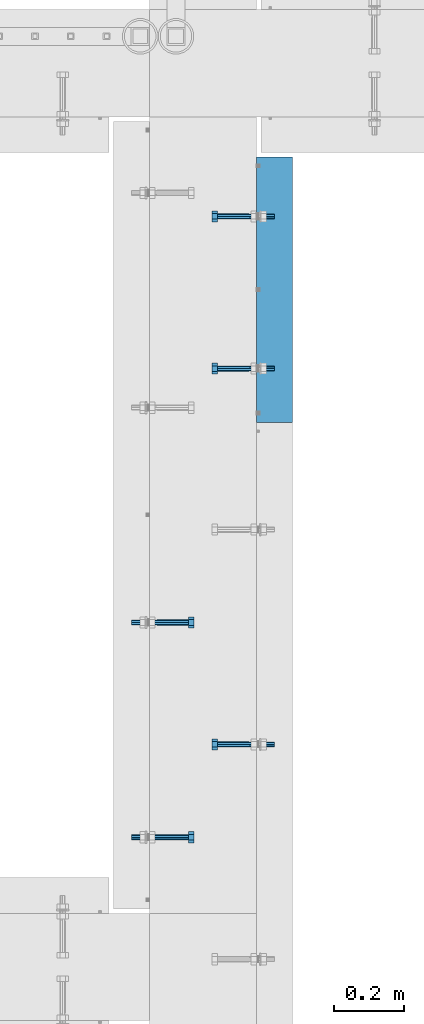
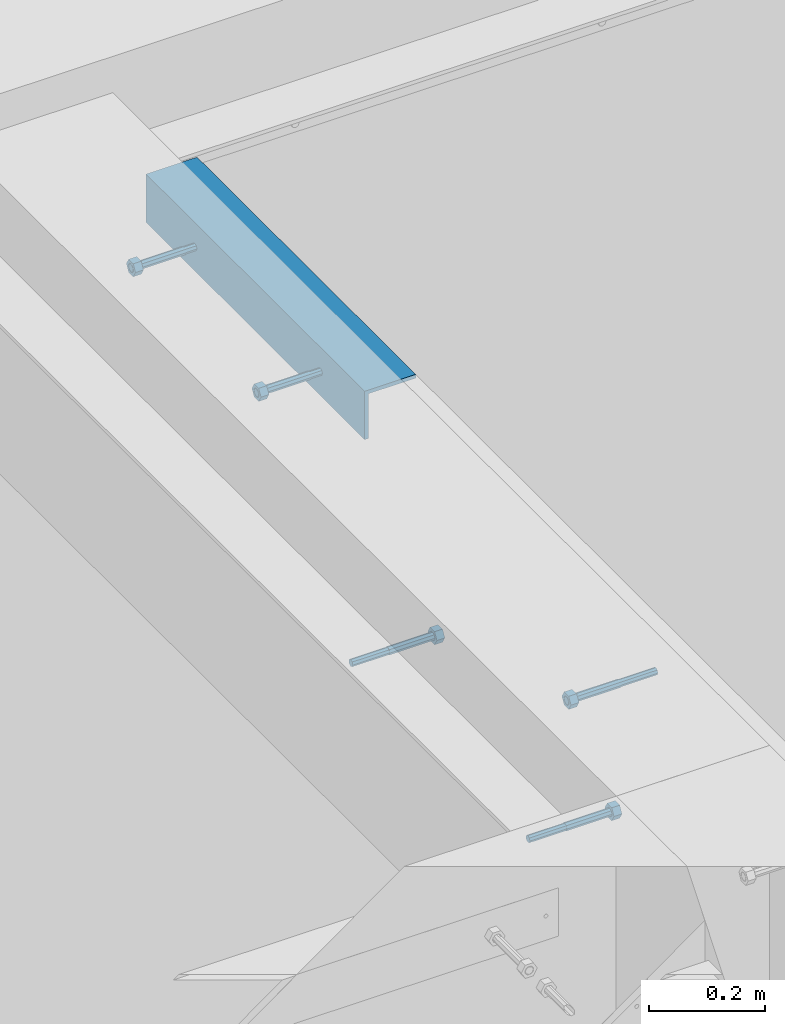
# One storey, part 424 of 975: 6 beams.
"""IFC2X3 building model written with IfcOpenShell, lengths in millimetres."""

import ifcopenshell
import ifcopenshell.guid

model = None  # the IFC model being written
_history = None  # IfcOwnerHistory: only IFC2X3 demands one
_inside = {}  # id of a spatial element -> (the spatial element, [elements in it])
_under = {}  # id of a project, library or spatial element -> (it, [spatial elements below it])
_declared = {}  # id of a project -> (the project, [libraries it declares])
_typed = {}  # id of a type object -> (the type object, [elements of that type])
_made_of = {}  # id of a material, layer set ... -> (it, [elements and type objects made of it])


def new_model(schema):
    """Start an empty IFC model of exactly this schema.

    Asked for "IFC4X3", IfcOpenShell would pick the latest addendum, in which some entities
    have other attributes; the version numbers below select the first issue.
    IFC2X3 requires an IfcOwnerHistory on every rooted entity: one is made here for all.
    """
    global model, _history
    if schema == "IFC4X3":
        model = ifcopenshell.file(schema_version=(4, 3, 0, 0))
    else:
        model = ifcopenshell.file(schema=schema)
    _inside.clear()
    _under.clear()
    _declared.clear()
    _typed.clear()
    _made_of.clear()
    _history = None
    if model.schema == "IFC2X3":
        org = make("IfcOrganization", Name="unknown")
        user = make(
            "IfcPersonAndOrganization",
            ThePerson=make("IfcPerson", FamilyName="unknown"),
            TheOrganization=org,
        )
        app = make(
            "IfcApplication",
            ApplicationDeveloper=org,
            Version="unknown",
            ApplicationFullName="unknown",
            ApplicationIdentifier="unknown",
        )
        _history = make(
            "IfcOwnerHistory",
            OwningUser=user,
            OwningApplication=app,
            ChangeAction="ADDED",
            CreationDate=0,
        )
    return model


def make(cls, **values):
    """One entity of the class cls with the attributes given. An attribute that is None is left unset."""
    return model.create_entity(
        cls, **{name: value for name, value in values.items() if value is not None}
    )


def rooted(cls, **values):
    """An entity with a GlobalId (a new one), such as an element, a storey or a relation."""
    return make(cls, GlobalId=ifcopenshell.guid.new(), OwnerHistory=_history, **values)


def si_unit(unit_type, name, prefix=None):
    """IfcSIUnit, for example si_unit("LENGTHUNIT", "METRE", prefix="MILLI")."""
    return make("IfcSIUnit", UnitType=unit_type, Prefix=prefix, Name=name)


def assignment(units):
    """IfcUnitAssignment: the units of a project."""
    return None if units is None else make("IfcUnitAssignment", Units=units)


def point(xyz):
    """IfcCartesianPoint."""
    return None if xyz is None else make("IfcCartesianPoint", Coordinates=xyz)


def direction(xyz):
    """IfcDirection."""
    return None if xyz is None else make("IfcDirection", DirectionRatios=xyz)


def frame(location, z_axis=None, x_axis=None):
    """IfcAxis2Placement3D, a coordinate frame: its origin and axes. An axis left out is left unset."""
    return make(
        "IfcAxis2Placement3D",
        Location=point(location),
        Axis=direction(z_axis),
        RefDirection=direction(x_axis),
    )


def origin_with_axes():
    """The frame at (0, 0, 0) with the z axis (0, 0, 1) and the x axis (1, 0, 0) written out."""
    return frame((0.0, 0.0, 0.0), z_axis=(0.0, 0.0, 1.0), x_axis=(1.0, 0.0, 0.0))


def place(relative_to, where):
    """IfcLocalPlacement: puts the frame where relative to a parent placement (None: the world)."""
    return make(
        "IfcLocalPlacement", PlacementRelTo=relative_to, RelativePlacement=where
    )


def context(
    kind, dimensions, precision=None, world=None, true_north=None, identifier=None
):
    """IfcGeometricRepresentationContext, for example the 3D "Model" context."""
    return make(
        "IfcGeometricRepresentationContext",
        ContextIdentifier=identifier,
        ContextType=kind,
        CoordinateSpaceDimension=dimensions,
        Precision=precision,
        WorldCoordinateSystem=world,
        TrueNorth=true_north,
    )


def subcontext(parent, identifier, kind, view, scale=None):
    """IfcGeometricRepresentationSubContext, for example "Body" below "Model"."""
    return make(
        "IfcGeometricRepresentationSubContext",
        ContextIdentifier=identifier,
        ContextType=kind,
        ParentContext=parent,
        TargetScale=scale,
        TargetView=view,
    )


def project(units=None, contexts=None):
    """IfcProject with its units and contexts."""
    return rooted(
        "IfcProject",
        Name="project",
        RepresentationContexts=contexts,
        UnitsInContext=assignment(units),
    )


def spatial(cls, under=None, at=None, **own):
    """A site, building, storey or space (cls), placed at a placement, below another one or the project."""
    s = rooted(cls, ObjectPlacement=at, **own)
    if under is not None:
        _under.setdefault(under.id(), (under, []))[1].append(s)
    return s


def faces_of(points, faces, orient=None, outer=None):
    """IfcFace entities. A face is a list of loops; a loop is a list of indices into points, from 0.

    orient and outer hold one flag for each loop. By default every Orientation is true, the
    first loop of a face is its IfcFaceOuterBound and the others are IfcFaceBound.
    """
    made = []
    for i, loops in enumerate(faces):
        bounds = []
        for j, loop in enumerate(loops):
            is_outer = j == 0 if outer is None else outer[i][j]
            bounds.append(
                make(
                    "IfcFaceOuterBound" if is_outer else "IfcFaceBound",
                    Bound=make("IfcPolyLoop", Polygon=[points[k] for k in loop]),
                    Orientation=True if orient is None else orient[i][j],
                )
            )
        made.append(make("IfcFace", Bounds=bounds))
    return made


def faceted_brep(points, faces, orient=None, outer=None, voids=None):
    """IfcFacetedBrep: a solid bounded by flat faces; with voids (closed shells), ...WithVoids."""
    shared = [point(p) for p in points]
    hull = make("IfcClosedShell", CfsFaces=faces_of(shared, faces, orient, outer))
    if voids is None:
        return make("IfcFacetedBrep", Outer=hull)
    return make(
        "IfcFacetedBrepWithVoids",
        Outer=hull,
        Voids=[
            make(cls, CfsFaces=faces_of(shared, fs, o, b)) for cls, fs, o, b in voids
        ],
    )


def shape(context_of_items, identifier, shape_type, items):
    """IfcShapeRepresentation: the items that make up one representation, for example the "Body"."""
    return make(
        "IfcShapeRepresentation",
        ContextOfItems=context_of_items,
        RepresentationIdentifier=identifier,
        RepresentationType=shape_type,
        Items=items,
    )


def material(Name=None, Category=None):
    """IfcMaterial."""
    return make("IfcMaterial", Name=Name, Category=Category)


def made_of(thing, what):
    """Note that an element or type object is made of a material, layer set ...; save() writes the relation."""
    if what is not None:
        _made_of.setdefault(what.id(), (what, []))[1].append(thing)
    return thing


def type_object(cls, material=None, **own):
    """A type object (cls), such as IfcWallType, which elements share."""
    return made_of(rooted(cls, **own), material)


def element(
    cls,
    number,
    at=None,
    inside=None,
    cuts=None,
    type_object=None,
    material=None,
    context=None,
    identifier="Body",
    shape_type=None,
    held_by="IfcProductDefinitionShape",
    body=None,
    shapes=None,
    **own,
):
    """One element of the class cls, such as IfcWall. Its Tag is "e" and its number.

    at: its placement. inside: the storey or other place that contains it. cuts: it is an
    opening in that element (IfcRelVoidsElement). A single representation is given by context,
    identifier, shape_type and body (its items); several are given by shapes. held_by: the class
    of the entity that holds the representations. save() writes the other relations.
    """
    e = rooted(cls, Tag="e%d" % number, ObjectPlacement=at, **own)
    if body is not None:
        shapes = [shape(context, identifier, shape_type, body)]
    if shapes is not None:
        e.Representation = make(held_by, Representations=shapes)
    if inside is not None:
        _inside.setdefault(inside.id(), (inside, []))[1].append(e)
    if cuts is not None:
        rooted(
            "IfcRelVoidsElement", RelatingBuildingElement=cuts, RelatedOpeningElement=e
        )
    if type_object is not None:
        _typed.setdefault(type_object.id(), (type_object, []))[1].append(e)
    return made_of(e, material)


def aggregate(whole, parts):
    """IfcRelAggregates: a whole, such as a stair, and the parts it consists of."""
    return rooted("IfcRelAggregates", RelatingObject=whole, RelatedObjects=parts)


def save(model, path):
    """Write the relations noted so far, then the file.

    IfcRelAggregates (storeys below a building ...), IfcRelContainedInSpatialStructure (elements
    in a storey), IfcRelDefinesByType, IfcRelAssociatesMaterial and IfcRelDeclares: one each for
    every whole, place, type object, material and project.
    """
    for whole, parts in _under.values():
        aggregate(whole, parts)
    for where, things in _inside.values():
        rooted(
            "IfcRelContainedInSpatialStructure",
            RelatedElements=things,
            RelatingStructure=where,
        )
    for kind, things in _typed.values():
        rooted("IfcRelDefinesByType", RelatedObjects=things, RelatingType=kind)
    for what, things in _made_of.values():
        rooted("IfcRelAssociatesMaterial", RelatedObjects=things, RelatingMaterial=what)
    for by, libraries in _declared.values():
        rooted("IfcRelDeclares", RelatingContext=by, RelatedDefinitions=libraries)
    model.write(path)


model = new_model("IFC2X3")

# Units and contexts
model_context = context("Model", 3, precision=1e-05, world=origin_with_axes())
body_context = subcontext(model_context, "Body", "Model", "MODEL_VIEW")
ifc_project = project(units=[si_unit("LENGTHUNIT", "METRE", prefix="MILLI"), si_unit("AREAUNIT", "SQUARE_METRE"), si_unit("VOLUMEUNIT", "CUBIC_METRE"), si_unit("MASSUNIT", "GRAM", prefix="KILO"), si_unit("TIMEUNIT", "SECOND"), si_unit("PLANEANGLEUNIT", "RADIAN"), si_unit("SOLIDANGLEUNIT", "STERADIAN"), si_unit("THERMODYNAMICTEMPERATUREUNIT", "DEGREE_CELSIUS"), si_unit("LUMINOUSINTENSITYUNIT", "LUMEN")], contexts=[model_context])

# Site, building, storey
site_placement = place(None, origin_with_axes())
site = spatial("IfcSite", under=ifc_project, at=site_placement, CompositionType="ELEMENT")
building_placement = place(site_placement, origin_with_axes())
building = spatial("IfcBuilding", under=site, at=building_placement, Name="Undefined", CompositionType="ELEMENT")
storey_placement = place(building_placement, origin_with_axes())
storey = spatial("IfcBuildingStorey", under=building, at=storey_placement, Name="Undefined", CompositionType="ELEMENT", Elevation=0.0)

# Beams
ifc_material_1 = material(Name="STEEL/F1554-36")
beam_type_1 = type_object("IfcBeamType", PredefinedType="NOTDEFINED")
beam_1_placement = place(storey_placement, frame((2298.70035208282, 19729.4500085305, 3886.2), z_axis=(0.0, 0.0, 1.0), x_axis=(-0.999999999999998, 6.90000001668524e-08, 0.0)))
element("IfcBeam", 1, at=beam_1_placement, inside=storey, type_object=beam_type_1, material=ifc_material_1, Name="HEADED_ANCHOR_BOLT", context=body_context, shape_type="Brep", body=[
    faceted_brep([(88.9000000184824, 7.94000001861696, -13.7499999799138), (88.8999999527368, 15.8800000758411, 2.00943759409711e-08), (104.774999952569, 15.8800001213949, 6.97191353538074e-08), (104.775000018315, 7.94000006417082, -13.7499999302891), (88.900000064019, -7.94000009583215, -13.7499999799147), (104.775000063852, -7.9400000502792, -13.74999993029), (88.9000000438027, -15.880000153059, 2.00925569515675e-08), (104.775000043643, -15.8800001075042, 6.9716406869702e-08), (88.8999999780608, -7.94000009583488, 13.7500000200998), (104.774999977893, -7.94000005028101, 13.7500000697237), (88.8999999325279, 7.94000001861514, 13.7500000201007), (104.774999932361, 7.940000064169, 13.7500000697246), (88.9000000119959, 3.78780480527439, -7.86545778426807), (88.8999999957159, 6.82538844544797, -5.4430656647246), (88.8999999799416, 8.51112018845743, -1.94260763148395), (88.8999999677944, 8.51112018845652, 1.94260767167179), (88.8999999616899, 6.82538844544615, 5.44306570491244), (88.8999999628249, 3.78780480527257, 7.86545782445592), (88.8999999709849, -3.86089595849626e-08, 8.72999956233434), (88.8999999845473, -3.7878048824914, 7.8654578244541), (88.9000000008309, -6.82538852266407, 5.44306570491153), (88.9000000166052, -8.51112026567444, 1.94260767166998), (88.9000000287488, -8.51112026567353, -1.94260763148577), (88.9000000348606, -6.82538852266407, -5.44306566472642), (88.9000000337182, -3.78780488248958, -7.86545778426898), (88.9000000255583, -3.86080500902608e-08, -8.72999952214832), (104.775000025395, 6.94581103743985e-09, -8.72999947252447), (104.775000011829, 3.78780485082825, -7.86545773464422), (104.774999995549, 6.82538849100092, -5.44306561510075), (104.774999979774, 8.51112023401038, -1.9426075818601), (104.774999967627, 8.51112023401038, 1.94260772129564), (104.774999961523, 6.82538849100092, 5.44306575453629), (104.774999962658, 3.78780485082643, 7.86545787407977), (104.774999970818, 6.94399204803631e-09, 8.7299996119591), (104.77499998438, -3.78780483693754, 7.86545787407886), (104.775000000664, -6.82538847711112, 5.44306575453538), (104.775000016438, -8.51112022012057, 1.94260772129473), (104.775000028581, -8.51112022012057, -1.94260758186101), (104.775000034693, -6.82538847711021, -5.44306561510166), (104.775000033551, -3.78780483693663, -7.86545773464422), (-2.99107341561466e-07, -5.61266007567065, 5.61266007566792), (-4.22995071858168e-07, -7.93750000000728, 0.0), (104.774999998088, -7.93749999999, -4.45652403868735e-11), (104.774999998088, -5.61266007565791, 5.61266007562426), (-1.09139364212751e-11, 1.81898940354586e-12, 7.9375), (104.774999998095, 1.18234311230481e-11, 7.93749999995816), (2.99089151667431e-07, 5.61266007567428, 5.61266007566792), (104.774999998102, 5.61266007568065, 5.61266007562517), (4.22980519942939e-07, 7.93750000001091, 0.0), (104.77499999811, 7.93750000001364, -4.36557456851006e-11), (2.99089151667431e-07, 5.61266007567428, -5.61266007566792), (104.774999998102, 5.61266007568156, -5.61266007571339), (-1.09139364212751e-11, 1.81898940354586e-12, -7.9375), (104.774999998099, 1.2732925824821e-11, -7.93750000004547), (-73.0249999592124, 5.05157065939329, -5.0515715445581), (-73.0249999269472, -1.85405951924622e-07, -7.14400069976364), (-73.0249999328516, -5.0515710302052, -5.05157154455992), (-73.0249999734697, -7.14400018541073, -6.9975976657588e-07), (-73.0250000250016, -5.05157103020611, 5.05157014504039), (-73.0250000572705, -1.85406861419324e-07, 7.1439993002441), (-73.0250000513661, 5.05157065939238, 5.05157014503948), (-73.025000010748, 7.14399981459792, -6.99758857081179e-07), (0.00625003290042514, 5.05157085007795, -5.05157087849238), (0.00625006516929716, 5.27870724909008e-09, -7.1440000336961), (0.00625005926485755, -5.05157083952145, -5.05157087849329), (0.00625001864682417, -7.14399999472516, -3.36940502165817e-08), (0.00624996711121639, -5.05157083952145, 5.05157081110519), (0.00624993484598235, 5.2777977543883e-09, 7.14399996631164), (0.00624994074678398, 5.05157085007704, 5.05157081110701), (0.00624998136845534, 7.14400000528167, -3.36922312271781e-08), (-2.99107341561466e-07, -5.61266007567065, -5.61266007566792), (104.774999998092, -5.612660075657, -5.6126600757143)], [[[0, 1, 2, 3]], [[4, 0, 3, 5]], [[6, 4, 5, 7]], [[8, 6, 7, 9]], [[10, 8, 9, 11]], [[0, 4, 6, 8, 10, 1], [12, 13, 14, 15, 16, 17, 18, 19, 20, 21, 22, 23, 24, 25]], [[12, 25, 26, 27]], [[13, 12, 27, 28]], [[14, 13, 28, 29]], [[15, 14, 29, 30]], [[16, 15, 30, 31]], [[17, 16, 31, 32]], [[18, 17, 32, 33]], [[19, 18, 33, 34]], [[20, 19, 34, 35]], [[21, 20, 35, 36]], [[22, 21, 36, 37]], [[23, 22, 37, 38]], [[24, 23, 38, 39]], [[25, 24, 39, 26]], [[9, 7, 5, 3, 2, 11], [38, 37, 36, 35, 34, 33, 32, 31, 30, 29, 28, 27, 26, 39]], [[1, 10, 11, 2]], [[40, 41, 42, 43]], [[44, 40, 43, 45]], [[46, 44, 45, 47]], [[48, 46, 47, 49]], [[50, 48, 49, 51]], [[52, 50, 51, 53]], [[54, 55, 56, 57, 58, 59, 60, 61]], [[55, 54, 62, 63]], [[56, 55, 63, 64]], [[57, 56, 64, 65]], [[58, 57, 65, 66]], [[59, 58, 66, 67]], [[60, 59, 67, 68]], [[61, 60, 68, 69]], [[54, 61, 69, 62]], [[40, 44, 46, 48, 50, 52, 70, 41], [68, 67, 66, 65, 64, 63, 62, 69]], [[41, 70, 71, 42]], [[53, 51, 49, 47, 45, 43, 42, 71]], [[70, 52, 53, 71]]]),
])
beam_2_placement = place(storey_placement, frame((2298.70029940322, 20161.2499779339, 3886.2), z_axis=(0.0, 0.0, -1.0), x_axis=(-0.999999999999998, 6.90000001668524e-08, 0.0)))
element("IfcBeam", 2, at=beam_2_placement, inside=storey, type_object=beam_type_1, material=ifc_material_1, Name="HEADED_ANCHOR_BOLT", context=body_context, shape_type="Brep", body=[
    faceted_brep([(88.9000000184824, 7.94000001861696, -13.7499999799138), (88.8999999527368, 15.8800000758411, 2.00943759409711e-08), (104.774999952569, 15.8800001213949, 6.97191353538074e-08), (104.775000018315, 7.94000006417082, -13.7499999302891), (88.900000064019, -7.94000009583215, -13.7499999799147), (104.775000063852, -7.9400000502792, -13.74999993029), (88.9000000438027, -15.880000153059, 2.00925569515675e-08), (104.775000043643, -15.8800001075042, 6.9716406869702e-08), (88.8999999780608, -7.94000009583488, 13.7500000200998), (104.774999977893, -7.94000005028101, 13.7500000697237), (88.8999999325279, 7.94000001861514, 13.7500000201007), (104.774999932361, 7.940000064169, 13.7500000697246), (88.9000000119959, 3.78780480527439, -7.86545778426807), (88.8999999957159, 6.82538844544797, -5.4430656647246), (88.8999999799416, 8.51112018845743, -1.94260763148395), (88.8999999677944, 8.51112018845652, 1.94260767167179), (88.8999999616899, 6.82538844544615, 5.44306570491244), (88.8999999628249, 3.78780480527257, 7.86545782445592), (88.8999999709849, -3.86089595849626e-08, 8.72999956233434), (88.8999999845473, -3.7878048824914, 7.8654578244541), (88.9000000008309, -6.82538852266407, 5.44306570491153), (88.9000000166052, -8.51112026567444, 1.94260767166998), (88.9000000287488, -8.51112026567353, -1.94260763148577), (88.9000000348606, -6.82538852266407, -5.44306566472642), (88.9000000337182, -3.78780488248958, -7.86545778426898), (88.9000000255583, -3.86080500902608e-08, -8.72999952214832), (104.775000025395, 6.94581103743985e-09, -8.72999947252447), (104.775000011829, 3.78780485082825, -7.86545773464422), (104.774999995549, 6.82538849100092, -5.44306561510075), (104.774999979774, 8.51112023401038, -1.9426075818601), (104.774999967627, 8.51112023401038, 1.94260772129564), (104.774999961523, 6.82538849100092, 5.44306575453629), (104.774999962658, 3.78780485082643, 7.86545787407977), (104.774999970818, 6.94399204803631e-09, 8.7299996119591), (104.77499998438, -3.78780483693754, 7.86545787407886), (104.775000000664, -6.82538847711112, 5.44306575453538), (104.775000016438, -8.51112022012057, 1.94260772129473), (104.775000028581, -8.51112022012057, -1.94260758186101), (104.775000034693, -6.82538847711021, -5.44306561510166), (104.775000033551, -3.78780483693663, -7.86545773464422), (-2.99107341561466e-07, -5.61266007567065, 5.61266007566792), (-4.22995071858168e-07, -7.93750000000728, 0.0), (104.774999998088, -7.93749999999, -4.45652403868735e-11), (104.774999998088, -5.61266007565791, 5.61266007562426), (-1.09139364212751e-11, 1.81898940354586e-12, 7.9375), (104.774999998095, 1.18234311230481e-11, 7.93749999995816), (2.99089151667431e-07, 5.61266007567428, 5.61266007566792), (104.774999998102, 5.61266007568065, 5.61266007562517), (4.22980519942939e-07, 7.93750000001091, 0.0), (104.77499999811, 7.93750000001364, -4.36557456851006e-11), (2.99089151667431e-07, 5.61266007567428, -5.61266007566792), (104.774999998102, 5.61266007568156, -5.61266007571339), (-1.09139364212751e-11, 1.81898940354586e-12, -7.9375), (104.774999998099, 1.2732925824821e-11, -7.93750000004547), (-73.0249999592124, 5.05157065939329, -5.0515715445581), (-73.0249999269472, -1.85405951924622e-07, -7.14400069976364), (-73.0249999328516, -5.0515710302052, -5.05157154455992), (-73.0249999734697, -7.14400018541073, -6.9975976657588e-07), (-73.0250000250016, -5.05157103020611, 5.05157014504039), (-73.0250000572705, -1.85406861419324e-07, 7.1439993002441), (-73.0250000513661, 5.05157065939238, 5.05157014503948), (-73.025000010748, 7.14399981459792, -6.99758857081179e-07), (0.00625003290042514, 5.05157085007795, -5.05157087849238), (0.00625006516929716, 5.27870724909008e-09, -7.1440000336961), (0.00625005926485755, -5.05157083952145, -5.05157087849329), (0.00625001864682417, -7.14399999472516, -3.36940502165817e-08), (0.00624996711121639, -5.05157083952145, 5.05157081110519), (0.00624993484598235, 5.2777977543883e-09, 7.14399996631164), (0.00624994074678398, 5.05157085007704, 5.05157081110701), (0.00624998136845534, 7.14400000528167, -3.36922312271781e-08), (-2.99107341561466e-07, -5.61266007567065, -5.61266007566792), (104.774999998092, -5.612660075657, -5.6126600757143)], [[[0, 1, 2, 3]], [[4, 0, 3, 5]], [[6, 4, 5, 7]], [[8, 6, 7, 9]], [[10, 8, 9, 11]], [[0, 4, 6, 8, 10, 1], [12, 13, 14, 15, 16, 17, 18, 19, 20, 21, 22, 23, 24, 25]], [[12, 25, 26, 27]], [[13, 12, 27, 28]], [[14, 13, 28, 29]], [[15, 14, 29, 30]], [[16, 15, 30, 31]], [[17, 16, 31, 32]], [[18, 17, 32, 33]], [[19, 18, 33, 34]], [[20, 19, 34, 35]], [[21, 20, 35, 36]], [[22, 21, 36, 37]], [[23, 22, 37, 38]], [[24, 23, 38, 39]], [[25, 24, 39, 26]], [[9, 7, 5, 3, 2, 11], [38, 37, 36, 35, 34, 33, 32, 31, 30, 29, 28, 27, 26, 39]], [[1, 10, 11, 2]], [[40, 41, 42, 43]], [[44, 40, 43, 45]], [[46, 44, 45, 47]], [[48, 46, 47, 49]], [[50, 48, 49, 51]], [[52, 50, 51, 53]], [[54, 55, 56, 57, 58, 59, 60, 61]], [[55, 54, 62, 63]], [[56, 55, 63, 64]], [[57, 56, 64, 65]], [[58, 57, 65, 66]], [[59, 58, 66, 67]], [[60, 59, 67, 68]], [[61, 60, 68, 69]], [[54, 61, 69, 62]], [[40, 44, 46, 48, 50, 52, 70, 41], [68, 67, 66, 65, 64, 63, 62, 69]], [[41, 70, 71, 42]], [[53, 51, 49, 47, 45, 43, 42, 71]], [[70, 52, 53, 71]]]),
])
beam_3_placement = place(storey_placement, frame((2298.70031673156, 18662.6499761124, 3886.2), z_axis=(0.0, 0.0, -1.0), x_axis=(-0.999999999999998, 6.90000001668524e-08, 0.0)))
element("IfcBeam", 3, at=beam_3_placement, inside=storey, type_object=beam_type_1, material=ifc_material_1, Name="HEADED_ANCHOR_BOLT", context=body_context, shape_type="Brep", body=[
    faceted_brep([(88.9000000184824, 7.94000001861696, -13.7499999799138), (88.8999999527368, 15.8800000758411, 2.00943759409711e-08), (104.774999952569, 15.8800001213949, 6.97191353538074e-08), (104.775000018315, 7.94000006417082, -13.7499999302891), (88.900000064019, -7.94000009583215, -13.7499999799147), (104.775000063852, -7.9400000502792, -13.74999993029), (88.9000000438027, -15.880000153059, 2.00925569515675e-08), (104.775000043643, -15.8800001075042, 6.9716406869702e-08), (88.8999999780608, -7.94000009583488, 13.7500000200998), (104.774999977893, -7.94000005028101, 13.7500000697237), (88.8999999325279, 7.94000001861514, 13.7500000201007), (104.774999932361, 7.940000064169, 13.7500000697246), (88.9000000119959, 3.78780480527439, -7.86545778426807), (88.8999999957159, 6.82538844544797, -5.4430656647246), (88.8999999799416, 8.51112018845743, -1.94260763148395), (88.8999999677944, 8.51112018845652, 1.94260767167179), (88.8999999616899, 6.82538844544615, 5.44306570491244), (88.8999999628249, 3.78780480527257, 7.86545782445592), (88.8999999709849, -3.86089595849626e-08, 8.72999956233434), (88.8999999845473, -3.7878048824914, 7.8654578244541), (88.9000000008309, -6.82538852266407, 5.44306570491153), (88.9000000166052, -8.51112026567444, 1.94260767166998), (88.9000000287488, -8.51112026567353, -1.94260763148577), (88.9000000348606, -6.82538852266407, -5.44306566472642), (88.9000000337182, -3.78780488248958, -7.86545778426898), (88.9000000255583, -3.86080500902608e-08, -8.72999952214832), (104.775000025395, 6.94581103743985e-09, -8.72999947252447), (104.775000011829, 3.78780485082825, -7.86545773464422), (104.774999995549, 6.82538849100092, -5.44306561510075), (104.774999979774, 8.51112023401038, -1.9426075818601), (104.774999967627, 8.51112023401038, 1.94260772129564), (104.774999961523, 6.82538849100092, 5.44306575453629), (104.774999962658, 3.78780485082643, 7.86545787407977), (104.774999970818, 6.94399204803631e-09, 8.7299996119591), (104.77499998438, -3.78780483693754, 7.86545787407886), (104.775000000664, -6.82538847711112, 5.44306575453538), (104.775000016438, -8.51112022012057, 1.94260772129473), (104.775000028581, -8.51112022012057, -1.94260758186101), (104.775000034693, -6.82538847711021, -5.44306561510166), (104.775000033551, -3.78780483693663, -7.86545773464422), (-2.99107341561466e-07, -5.61266007567065, 5.61266007566792), (-4.22995071858168e-07, -7.93750000000728, 0.0), (104.774999998088, -7.93749999999, -4.45652403868735e-11), (104.774999998088, -5.61266007565791, 5.61266007562426), (-1.09139364212751e-11, 1.81898940354586e-12, 7.9375), (104.774999998095, 1.18234311230481e-11, 7.93749999995816), (2.99089151667431e-07, 5.61266007567428, 5.61266007566792), (104.774999998102, 5.61266007568065, 5.61266007562517), (4.22980519942939e-07, 7.93750000001091, 0.0), (104.77499999811, 7.93750000001364, -4.36557456851006e-11), (2.99089151667431e-07, 5.61266007567428, -5.61266007566792), (104.774999998102, 5.61266007568156, -5.61266007571339), (-1.09139364212751e-11, 1.81898940354586e-12, -7.9375), (104.774999998099, 1.2732925824821e-11, -7.93750000004547), (-73.0249999592124, 5.05157065939329, -5.0515715445581), (-73.0249999269472, -1.85405951924622e-07, -7.14400069976364), (-73.0249999328516, -5.0515710302052, -5.05157154455992), (-73.0249999734697, -7.14400018541073, -6.9975976657588e-07), (-73.0250000250016, -5.05157103020611, 5.05157014504039), (-73.0250000572705, -1.85406861419324e-07, 7.1439993002441), (-73.0250000513661, 5.05157065939238, 5.05157014503948), (-73.025000010748, 7.14399981459792, -6.99758857081179e-07), (0.00625003290042514, 5.05157085007795, -5.05157087849238), (0.00625006516929716, 5.27870724909008e-09, -7.1440000336961), (0.00625005926485755, -5.05157083952145, -5.05157087849329), (0.00625001864682417, -7.14399999472516, -3.36940502165817e-08), (0.00624996711121639, -5.05157083952145, 5.05157081110519), (0.00624993484598235, 5.2777977543883e-09, 7.14399996631164), (0.00624994074678398, 5.05157085007704, 5.05157081110701), (0.00624998136845534, 7.14400000528167, -3.36922312271781e-08), (-2.99107341561466e-07, -5.61266007567065, -5.61266007566792), (104.774999998092, -5.612660075657, -5.6126600757143)], [[[0, 1, 2, 3]], [[4, 0, 3, 5]], [[6, 4, 5, 7]], [[8, 6, 7, 9]], [[10, 8, 9, 11]], [[0, 4, 6, 8, 10, 1], [12, 13, 14, 15, 16, 17, 18, 19, 20, 21, 22, 23, 24, 25]], [[12, 25, 26, 27]], [[13, 12, 27, 28]], [[14, 13, 28, 29]], [[15, 14, 29, 30]], [[16, 15, 30, 31]], [[17, 16, 31, 32]], [[18, 17, 32, 33]], [[19, 18, 33, 34]], [[20, 19, 34, 35]], [[21, 20, 35, 36]], [[22, 21, 36, 37]], [[23, 22, 37, 38]], [[24, 23, 38, 39]], [[25, 24, 39, 26]], [[9, 7, 5, 3, 2, 11], [38, 37, 36, 35, 34, 33, 32, 31, 30, 29, 28, 27, 26, 39]], [[1, 10, 11, 2]], [[40, 41, 42, 43]], [[44, 40, 43, 45]], [[46, 44, 45, 47]], [[48, 46, 47, 49]], [[50, 48, 49, 51]], [[52, 50, 51, 53]], [[54, 55, 56, 57, 58, 59, 60, 61]], [[55, 54, 62, 63]], [[56, 55, 63, 64]], [[57, 56, 64, 65]], [[58, 57, 65, 66]], [[59, 58, 66, 67]], [[60, 59, 67, 68]], [[61, 60, 68, 69]], [[54, 61, 69, 62]], [[40, 44, 46, 48, 50, 52, 70, 41], [68, 67, 66, 65, 64, 63, 62, 69]], [[41, 70, 71, 42]], [[53, 51, 49, 47, 45, 43, 42, 71]], [[70, 52, 53, 71]]]),
])
beam_4_placement = place(storey_placement, frame((2038.35000050607, 19008.72495102, 3835.4), z_axis=(0.0, 0.0, -1.0), x_axis=(1.0, 0.0, 0.0)))
element("IfcBeam", 4, at=beam_4_placement, inside=storey, type_object=beam_type_1, material=ifc_material_1, Name="HEADED_ANCHOR_BOLT", context=body_context, shape_type="Brep", body=[
    faceted_brep([(88.9000000184824, 7.94000001861696, -13.7499999799138), (88.8999999527368, 15.8800000758411, 2.00943759409711e-08), (104.774999952569, 15.8800001213949, 6.97191353538074e-08), (104.775000018315, 7.94000006417082, -13.7499999302891), (88.900000064019, -7.94000009583215, -13.7499999799147), (104.775000063852, -7.9400000502792, -13.74999993029), (88.9000000438027, -15.880000153059, 2.00925569515675e-08), (104.775000043643, -15.8800001075042, 6.9716406869702e-08), (88.8999999780608, -7.94000009583488, 13.7500000200998), (104.774999977893, -7.94000005028101, 13.7500000697237), (88.8999999325279, 7.94000001861514, 13.7500000201007), (104.774999932361, 7.940000064169, 13.7500000697246), (88.9000000119959, 3.78780480527439, -7.86545778426807), (88.8999999957159, 6.82538844544797, -5.4430656647246), (88.8999999799416, 8.51112018845743, -1.94260763148395), (88.8999999677944, 8.51112018845652, 1.94260767167179), (88.8999999616899, 6.82538844544615, 5.44306570491244), (88.8999999628249, 3.78780480527257, 7.86545782445592), (88.8999999709849, -3.86089595849626e-08, 8.72999956233434), (88.8999999845473, -3.7878048824914, 7.8654578244541), (88.9000000008309, -6.82538852266407, 5.44306570491153), (88.9000000166052, -8.51112026567444, 1.94260767166998), (88.9000000287488, -8.51112026567353, -1.94260763148577), (88.9000000348606, -6.82538852266407, -5.44306566472642), (88.9000000337182, -3.78780488248958, -7.86545778426898), (88.9000000255583, -3.86080500902608e-08, -8.72999952214832), (104.775000025395, 6.94581103743985e-09, -8.72999947252447), (104.775000011829, 3.78780485082825, -7.86545773464422), (104.774999995549, 6.82538849100092, -5.44306561510075), (104.774999979774, 8.51112023401038, -1.9426075818601), (104.774999967627, 8.51112023401038, 1.94260772129564), (104.774999961523, 6.82538849100092, 5.44306575453629), (104.774999962658, 3.78780485082643, 7.86545787407977), (104.774999970818, 6.94399204803631e-09, 8.7299996119591), (104.77499998438, -3.78780483693754, 7.86545787407886), (104.775000000664, -6.82538847711112, 5.44306575453538), (104.775000016438, -8.51112022012057, 1.94260772129473), (104.775000028581, -8.51112022012057, -1.94260758186101), (104.775000034693, -6.82538847711021, -5.44306561510166), (104.775000033551, -3.78780483693663, -7.86545773464422), (-2.99107341561466e-07, -5.61266007567065, 5.61266007566792), (-4.22995071858168e-07, -7.93750000000728, 0.0), (104.774999998088, -7.93749999999, -4.45652403868735e-11), (104.774999998088, -5.61266007565791, 5.61266007562426), (-1.09139364212751e-11, 1.81898940354586e-12, 7.9375), (104.774999998095, 1.18234311230481e-11, 7.93749999995816), (2.99089151667431e-07, 5.61266007567428, 5.61266007566792), (104.774999998102, 5.61266007568065, 5.61266007562517), (4.22980519942939e-07, 7.93750000001091, 0.0), (104.77499999811, 7.93750000001364, -4.36557456851006e-11), (2.99089151667431e-07, 5.61266007567428, -5.61266007566792), (104.774999998102, 5.61266007568156, -5.61266007571339), (-1.09139364212751e-11, 1.81898940354586e-12, -7.9375), (104.774999998099, 1.2732925824821e-11, -7.93750000004547), (-73.0249999592124, 5.05157065939329, -5.0515715445581), (-73.0249999269472, -1.85405951924622e-07, -7.14400069976364), (-73.0249999328516, -5.0515710302052, -5.05157154455992), (-73.0249999734697, -7.14400018541073, -6.9975976657588e-07), (-73.0250000250016, -5.05157103020611, 5.05157014504039), (-73.0250000572705, -1.85406861419324e-07, 7.1439993002441), (-73.0250000513661, 5.05157065939238, 5.05157014503948), (-73.025000010748, 7.14399981459792, -6.99758857081179e-07), (0.00625003290042514, 5.05157085007795, -5.05157087849238), (0.00625006516929716, 5.27870724909008e-09, -7.1440000336961), (0.00625005926485755, -5.05157083952145, -5.05157087849329), (0.00625001864682417, -7.14399999472516, -3.36940502165817e-08), (0.00624996711121639, -5.05157083952145, 5.05157081110519), (0.00624993484598235, 5.2777977543883e-09, 7.14399996631164), (0.00624994074678398, 5.05157085007704, 5.05157081110701), (0.00624998136845534, 7.14400000528167, -3.36922312271781e-08), (-2.99107341561466e-07, -5.61266007567065, -5.61266007566792), (104.774999998092, -5.612660075657, -5.6126600757143)], [[[0, 1, 2, 3]], [[4, 0, 3, 5]], [[6, 4, 5, 7]], [[8, 6, 7, 9]], [[10, 8, 9, 11]], [[0, 4, 6, 8, 10, 1], [12, 13, 14, 15, 16, 17, 18, 19, 20, 21, 22, 23, 24, 25]], [[12, 25, 26, 27]], [[13, 12, 27, 28]], [[14, 13, 28, 29]], [[15, 14, 29, 30]], [[16, 15, 30, 31]], [[17, 16, 31, 32]], [[18, 17, 32, 33]], [[19, 18, 33, 34]], [[20, 19, 34, 35]], [[21, 20, 35, 36]], [[22, 21, 36, 37]], [[23, 22, 37, 38]], [[24, 23, 38, 39]], [[25, 24, 39, 26]], [[9, 7, 5, 3, 2, 11], [38, 37, 36, 35, 34, 33, 32, 31, 30, 29, 28, 27, 26, 39]], [[1, 10, 11, 2]], [[40, 41, 42, 43]], [[44, 40, 43, 45]], [[46, 44, 45, 47]], [[48, 46, 47, 49]], [[50, 48, 49, 51]], [[52, 50, 51, 53]], [[54, 55, 56, 57, 58, 59, 60, 61]], [[55, 54, 62, 63]], [[56, 55, 63, 64]], [[57, 56, 64, 65]], [[58, 57, 65, 66]], [[59, 58, 66, 67]], [[60, 59, 67, 68]], [[61, 60, 68, 69]], [[54, 61, 69, 62]], [[40, 44, 46, 48, 50, 52, 70, 41], [68, 67, 66, 65, 64, 63, 62, 69]], [[41, 70, 71, 42]], [[53, 51, 49, 47, 45, 43, 42, 71]], [[70, 52, 53, 71]]]),
])
beam_5_placement = place(storey_placement, frame((2038.34999623887, 18399.1249754341, 3835.4), z_axis=(0.0, 0.0, -1.0), x_axis=(1.0, 0.0, 0.0)))
element("IfcBeam", 5, at=beam_5_placement, inside=storey, type_object=beam_type_1, material=ifc_material_1, Name="HEADED_ANCHOR_BOLT", context=body_context, shape_type="Brep", body=[
    faceted_brep([(88.9000000184824, 7.94000001861696, -13.7499999799138), (88.8999999527368, 15.8800000758411, 2.00943759409711e-08), (104.774999952569, 15.8800001213949, 6.97191353538074e-08), (104.775000018315, 7.94000006417082, -13.7499999302891), (88.900000064019, -7.94000009583215, -13.7499999799147), (104.775000063852, -7.9400000502792, -13.74999993029), (88.9000000438027, -15.880000153059, 2.00925569515675e-08), (104.775000043643, -15.8800001075042, 6.9716406869702e-08), (88.8999999780608, -7.94000009583488, 13.7500000200998), (104.774999977893, -7.94000005028101, 13.7500000697237), (88.8999999325279, 7.94000001861514, 13.7500000201007), (104.774999932361, 7.940000064169, 13.7500000697246), (88.9000000119959, 3.78780480527439, -7.86545778426807), (88.8999999957159, 6.82538844544797, -5.4430656647246), (88.8999999799416, 8.51112018845743, -1.94260763148395), (88.8999999677944, 8.51112018845652, 1.94260767167179), (88.8999999616899, 6.82538844544615, 5.44306570491244), (88.8999999628249, 3.78780480527257, 7.86545782445592), (88.8999999709849, -3.86089595849626e-08, 8.72999956233434), (88.8999999845473, -3.7878048824914, 7.8654578244541), (88.9000000008309, -6.82538852266407, 5.44306570491153), (88.9000000166052, -8.51112026567444, 1.94260767166998), (88.9000000287488, -8.51112026567353, -1.94260763148577), (88.9000000348606, -6.82538852266407, -5.44306566472642), (88.9000000337182, -3.78780488248958, -7.86545778426898), (88.9000000255583, -3.86080500902608e-08, -8.72999952214832), (104.775000025395, 6.94581103743985e-09, -8.72999947252447), (104.775000011829, 3.78780485082825, -7.86545773464422), (104.774999995549, 6.82538849100092, -5.44306561510075), (104.774999979774, 8.51112023401038, -1.9426075818601), (104.774999967627, 8.51112023401038, 1.94260772129564), (104.774999961523, 6.82538849100092, 5.44306575453629), (104.774999962658, 3.78780485082643, 7.86545787407977), (104.774999970818, 6.94399204803631e-09, 8.7299996119591), (104.77499998438, -3.78780483693754, 7.86545787407886), (104.775000000664, -6.82538847711112, 5.44306575453538), (104.775000016438, -8.51112022012057, 1.94260772129473), (104.775000028581, -8.51112022012057, -1.94260758186101), (104.775000034693, -6.82538847711021, -5.44306561510166), (104.775000033551, -3.78780483693663, -7.86545773464422), (-2.99107341561466e-07, -5.61266007567065, 5.61266007566792), (-4.22995071858168e-07, -7.93750000000728, 0.0), (104.774999998088, -7.93749999999, -4.45652403868735e-11), (104.774999998088, -5.61266007565791, 5.61266007562426), (-1.09139364212751e-11, 1.81898940354586e-12, 7.9375), (104.774999998095, 1.18234311230481e-11, 7.93749999995816), (2.99089151667431e-07, 5.61266007567428, 5.61266007566792), (104.774999998102, 5.61266007568065, 5.61266007562517), (4.22980519942939e-07, 7.93750000001091, 0.0), (104.77499999811, 7.93750000001364, -4.36557456851006e-11), (2.99089151667431e-07, 5.61266007567428, -5.61266007566792), (104.774999998102, 5.61266007568156, -5.61266007571339), (-1.09139364212751e-11, 1.81898940354586e-12, -7.9375), (104.774999998099, 1.2732925824821e-11, -7.93750000004547), (-73.0249999592124, 5.05157065939329, -5.0515715445581), (-73.0249999269472, -1.85405951924622e-07, -7.14400069976364), (-73.0249999328516, -5.0515710302052, -5.05157154455992), (-73.0249999734697, -7.14400018541073, -6.9975976657588e-07), (-73.0250000250016, -5.05157103020611, 5.05157014504039), (-73.0250000572705, -1.85406861419324e-07, 7.1439993002441), (-73.0250000513661, 5.05157065939238, 5.05157014503948), (-73.025000010748, 7.14399981459792, -6.99758857081179e-07), (0.00625003290042514, 5.05157085007795, -5.05157087849238), (0.00625006516929716, 5.27870724909008e-09, -7.1440000336961), (0.00625005926485755, -5.05157083952145, -5.05157087849329), (0.00625001864682417, -7.14399999472516, -3.36940502165817e-08), (0.00624996711121639, -5.05157083952145, 5.05157081110519), (0.00624993484598235, 5.2777977543883e-09, 7.14399996631164), (0.00624994074678398, 5.05157085007704, 5.05157081110701), (0.00624998136845534, 7.14400000528167, -3.36922312271781e-08), (-2.99107341561466e-07, -5.61266007567065, -5.61266007566792), (104.774999998092, -5.612660075657, -5.6126600757143)], [[[0, 1, 2, 3]], [[4, 0, 3, 5]], [[6, 4, 5, 7]], [[8, 6, 7, 9]], [[10, 8, 9, 11]], [[0, 4, 6, 8, 10, 1], [12, 13, 14, 15, 16, 17, 18, 19, 20, 21, 22, 23, 24, 25]], [[12, 25, 26, 27]], [[13, 12, 27, 28]], [[14, 13, 28, 29]], [[15, 14, 29, 30]], [[16, 15, 30, 31]], [[17, 16, 31, 32]], [[18, 17, 32, 33]], [[19, 18, 33, 34]], [[20, 19, 34, 35]], [[21, 20, 35, 36]], [[22, 21, 36, 37]], [[23, 22, 37, 38]], [[24, 23, 38, 39]], [[25, 24, 39, 26]], [[9, 7, 5, 3, 2, 11], [38, 37, 36, 35, 34, 33, 32, 31, 30, 29, 28, 27, 26, 39]], [[1, 10, 11, 2]], [[40, 41, 42, 43]], [[44, 40, 43, 45]], [[46, 44, 45, 47]], [[48, 46, 47, 49]], [[50, 48, 49, 51]], [[52, 50, 51, 53]], [[54, 55, 56, 57, 58, 59, 60, 61]], [[55, 54, 62, 63]], [[56, 55, 63, 64]], [[57, 56, 64, 65]], [[58, 57, 65, 66]], [[59, 58, 66, 67]], [[60, 59, 67, 68]], [[61, 60, 68, 69]], [[54, 61, 69, 62]], [[40, 44, 46, 48, 50, 52, 70, 41], [68, 67, 66, 65, 64, 63, 62, 69]], [[41, 70, 71, 42]], [[53, 51, 49, 47, 45, 43, 42, 71]], [[70, 52, 53, 71]]]),
])
ifc_material_2 = material(Name="STEEL/A36")
beam_type_2 = type_object("IfcBeamType", Name="L4X4X5/16", PredefinedType="NOTDEFINED")
beam_6_placement = place(storey_placement, frame((2371.72537067562, 19577.0500061884, 3886.2), z_axis=(1.0, 0.0, 0.0), x_axis=(0.0, 1.0, 0.0)))
element("IfcBeam", 6, at=beam_6_placement, inside=storey, type_object=beam_type_2, material=ifc_material_2, Name="LEDGER_ANGLE", ObjectType="L4X4X5/16", context=body_context, shape_type="Brep", body=[
    faceted_brep([(-1.90993887372315e-11, 50.8000000000002, -50.8), (2.00088834390044e-11, 50.8000000000002, 50.8), (752.474998452519, 50.8000000000002, 50.7999999999452), (752.474998452559, 50.8000000000002, -50.8000000000561), (2.00088834390044e-11, 42.8625000000002, 50.8), (752.474998452519, 42.8625000000002, 50.7999999999452), (-1.63709046319127e-11, 42.8625000000002, -42.8625), (752.474998452555, 42.8625000000002, -42.8625000000557), (-1.63709046319127e-11, -50.8000000000002, -42.8625), (752.474998452555, -50.8000000000002, -42.8625000000557), (-1.90993887372315e-11, -50.8000000000002, -50.8), (752.474998452559, -50.8000000000002, -50.8000000000561)], [[[0, 1, 2, 3]], [[1, 4, 5, 2]], [[4, 6, 7, 5]], [[6, 8, 9, 7]], [[8, 10, 11, 9]], [[10, 0, 3, 11]], [[5, 7, 9, 11, 3, 2]], [[10, 8, 6, 4, 1, 0]]]),
])

save(model, "model.ifc")
